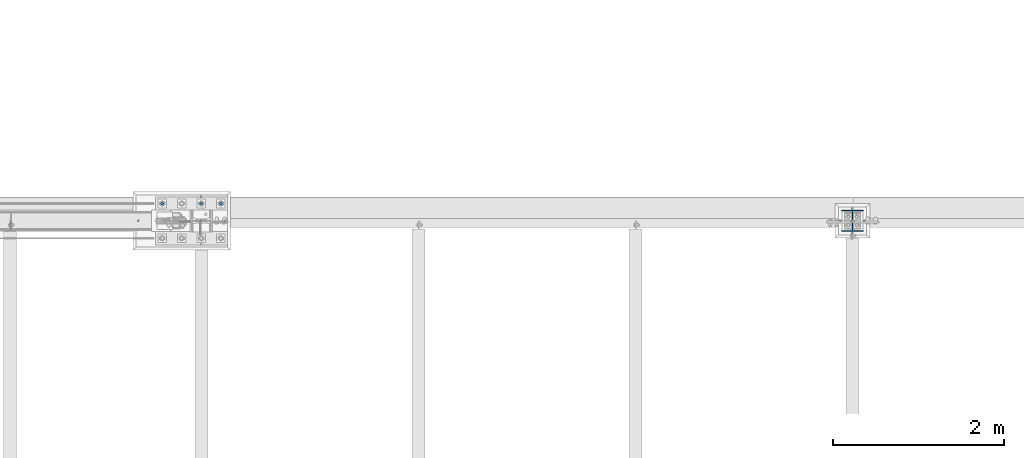
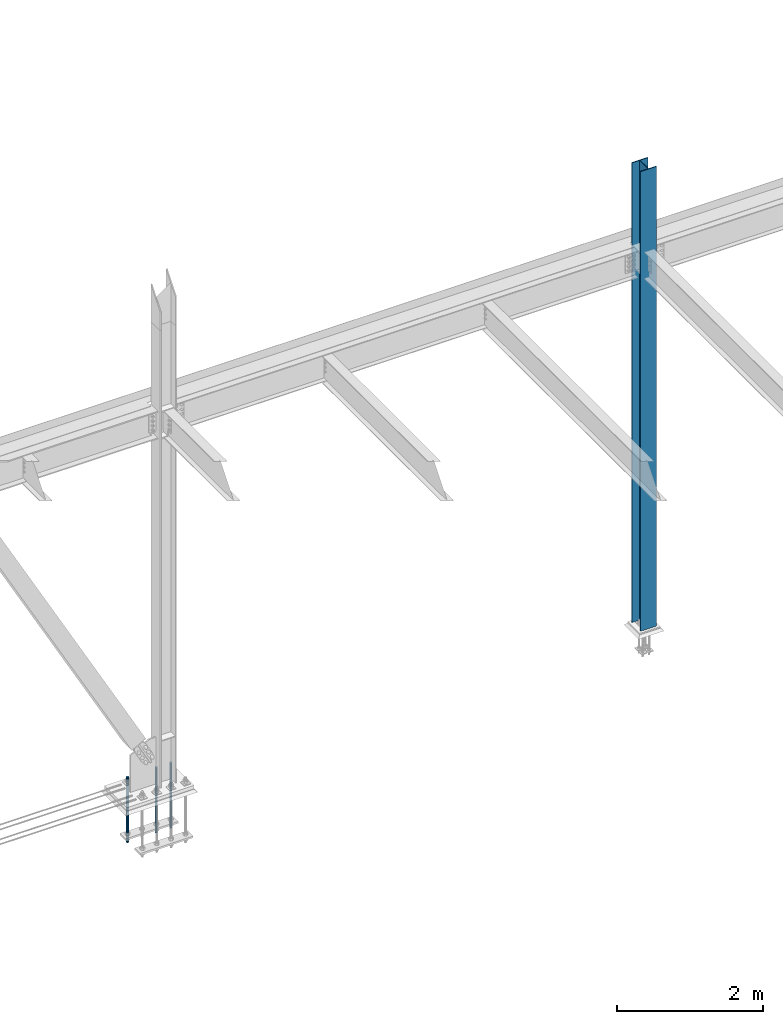
# One storey, part 1401 of 3843: 4 columns, 2 elements without a shape of their own.
"""IFC2X3 building model written with IfcOpenShell, lengths in millimetres."""

import ifcopenshell
import ifcopenshell.guid

model = None  # the IFC model being written
_history = None  # IfcOwnerHistory: only IFC2X3 demands one
_inside = {}  # id of a spatial element -> (the spatial element, [elements in it])
_under = {}  # id of a project, library or spatial element -> (it, [spatial elements below it])
_declared = {}  # id of a project -> (the project, [libraries it declares])
_typed = {}  # id of a type object -> (the type object, [elements of that type])
_made_of = {}  # id of a material, layer set ... -> (it, [elements and type objects made of it])


def new_model(schema):
    """Start an empty IFC model of exactly this schema.

    Asked for "IFC4X3", IfcOpenShell would pick the latest addendum, in which some entities
    have other attributes; the version numbers below select the first issue.
    IFC2X3 requires an IfcOwnerHistory on every rooted entity: one is made here for all.
    """
    global model, _history
    if schema == "IFC4X3":
        model = ifcopenshell.file(schema_version=(4, 3, 0, 0))
    else:
        model = ifcopenshell.file(schema=schema)
    _inside.clear()
    _under.clear()
    _declared.clear()
    _typed.clear()
    _made_of.clear()
    _history = None
    if model.schema == "IFC2X3":
        org = make("IfcOrganization", Name="unknown")
        user = make(
            "IfcPersonAndOrganization",
            ThePerson=make("IfcPerson", FamilyName="unknown"),
            TheOrganization=org,
        )
        app = make(
            "IfcApplication",
            ApplicationDeveloper=org,
            Version="unknown",
            ApplicationFullName="unknown",
            ApplicationIdentifier="unknown",
        )
        _history = make(
            "IfcOwnerHistory",
            OwningUser=user,
            OwningApplication=app,
            ChangeAction="ADDED",
            CreationDate=0,
        )
    return model


def make(cls, **values):
    """One entity of the class cls with the attributes given. An attribute that is None is left unset."""
    return model.create_entity(
        cls, **{name: value for name, value in values.items() if value is not None}
    )


def rooted(cls, **values):
    """An entity with a GlobalId (a new one), such as an element, a storey or a relation."""
    return make(cls, GlobalId=ifcopenshell.guid.new(), OwnerHistory=_history, **values)


def si_unit(unit_type, name, prefix=None):
    """IfcSIUnit, for example si_unit("LENGTHUNIT", "METRE", prefix="MILLI")."""
    return make("IfcSIUnit", UnitType=unit_type, Prefix=prefix, Name=name)


def assignment(units):
    """IfcUnitAssignment: the units of a project."""
    return None if units is None else make("IfcUnitAssignment", Units=units)


def point(xyz):
    """IfcCartesianPoint."""
    return None if xyz is None else make("IfcCartesianPoint", Coordinates=xyz)


def direction(xyz):
    """IfcDirection."""
    return None if xyz is None else make("IfcDirection", DirectionRatios=xyz)


def frame(location, z_axis=None, x_axis=None):
    """IfcAxis2Placement3D, a coordinate frame: its origin and axes. An axis left out is left unset."""
    return make(
        "IfcAxis2Placement3D",
        Location=point(location),
        Axis=direction(z_axis),
        RefDirection=direction(x_axis),
    )


def origin_with_axes():
    """The frame at (0, 0, 0) with the z axis (0, 0, 1) and the x axis (1, 0, 0) written out."""
    return frame((0.0, 0.0, 0.0), z_axis=(0.0, 0.0, 1.0), x_axis=(1.0, 0.0, 0.0))


def place(relative_to, where):
    """IfcLocalPlacement: puts the frame where relative to a parent placement (None: the world)."""
    return make(
        "IfcLocalPlacement", PlacementRelTo=relative_to, RelativePlacement=where
    )


def context(
    kind, dimensions, precision=None, world=None, true_north=None, identifier=None
):
    """IfcGeometricRepresentationContext, for example the 3D "Model" context."""
    return make(
        "IfcGeometricRepresentationContext",
        ContextIdentifier=identifier,
        ContextType=kind,
        CoordinateSpaceDimension=dimensions,
        Precision=precision,
        WorldCoordinateSystem=world,
        TrueNorth=true_north,
    )


def subcontext(parent, identifier, kind, view, scale=None):
    """IfcGeometricRepresentationSubContext, for example "Body" below "Model"."""
    return make(
        "IfcGeometricRepresentationSubContext",
        ContextIdentifier=identifier,
        ContextType=kind,
        ParentContext=parent,
        TargetScale=scale,
        TargetView=view,
    )


def project(units=None, contexts=None):
    """IfcProject with its units and contexts."""
    return rooted(
        "IfcProject",
        Name="project",
        RepresentationContexts=contexts,
        UnitsInContext=assignment(units),
    )


def spatial(cls, under=None, at=None, **own):
    """A site, building, storey or space (cls), placed at a placement, below another one or the project."""
    s = rooted(cls, ObjectPlacement=at, **own)
    if under is not None:
        _under.setdefault(under.id(), (under, []))[1].append(s)
    return s


def faces_of(points, faces, orient=None, outer=None):
    """IfcFace entities. A face is a list of loops; a loop is a list of indices into points, from 0.

    orient and outer hold one flag for each loop. By default every Orientation is true, the
    first loop of a face is its IfcFaceOuterBound and the others are IfcFaceBound.
    """
    made = []
    for i, loops in enumerate(faces):
        bounds = []
        for j, loop in enumerate(loops):
            is_outer = j == 0 if outer is None else outer[i][j]
            bounds.append(
                make(
                    "IfcFaceOuterBound" if is_outer else "IfcFaceBound",
                    Bound=make("IfcPolyLoop", Polygon=[points[k] for k in loop]),
                    Orientation=True if orient is None else orient[i][j],
                )
            )
        made.append(make("IfcFace", Bounds=bounds))
    return made


def faceted_brep(points, faces, orient=None, outer=None, voids=None):
    """IfcFacetedBrep: a solid bounded by flat faces; with voids (closed shells), ...WithVoids."""
    shared = [point(p) for p in points]
    hull = make("IfcClosedShell", CfsFaces=faces_of(shared, faces, orient, outer))
    if voids is None:
        return make("IfcFacetedBrep", Outer=hull)
    return make(
        "IfcFacetedBrepWithVoids",
        Outer=hull,
        Voids=[
            make(cls, CfsFaces=faces_of(shared, fs, o, b)) for cls, fs, o, b in voids
        ],
    )


def shape(context_of_items, identifier, shape_type, items):
    """IfcShapeRepresentation: the items that make up one representation, for example the "Body"."""
    return make(
        "IfcShapeRepresentation",
        ContextOfItems=context_of_items,
        RepresentationIdentifier=identifier,
        RepresentationType=shape_type,
        Items=items,
    )


def material(Name=None, Category=None):
    """IfcMaterial."""
    return make("IfcMaterial", Name=Name, Category=Category)


def made_of(thing, what):
    """Note that an element or type object is made of a material, layer set ...; save() writes the relation."""
    if what is not None:
        _made_of.setdefault(what.id(), (what, []))[1].append(thing)
    return thing


def type_object(cls, material=None, **own):
    """A type object (cls), such as IfcWallType, which elements share."""
    return made_of(rooted(cls, **own), material)


def element(
    cls,
    number,
    at=None,
    inside=None,
    cuts=None,
    type_object=None,
    material=None,
    context=None,
    identifier="Body",
    shape_type=None,
    held_by="IfcProductDefinitionShape",
    body=None,
    shapes=None,
    **own,
):
    """One element of the class cls, such as IfcWall. Its Tag is "e" and its number.

    at: its placement. inside: the storey or other place that contains it. cuts: it is an
    opening in that element (IfcRelVoidsElement). A single representation is given by context,
    identifier, shape_type and body (its items); several are given by shapes. held_by: the class
    of the entity that holds the representations. save() writes the other relations.
    """
    e = rooted(cls, Tag="e%d" % number, ObjectPlacement=at, **own)
    if body is not None:
        shapes = [shape(context, identifier, shape_type, body)]
    if shapes is not None:
        e.Representation = make(held_by, Representations=shapes)
    if inside is not None:
        _inside.setdefault(inside.id(), (inside, []))[1].append(e)
    if cuts is not None:
        rooted(
            "IfcRelVoidsElement", RelatingBuildingElement=cuts, RelatedOpeningElement=e
        )
    if type_object is not None:
        _typed.setdefault(type_object.id(), (type_object, []))[1].append(e)
    return made_of(e, material)


def aggregate(whole, parts):
    """IfcRelAggregates: a whole, such as a stair, and the parts it consists of."""
    return rooted("IfcRelAggregates", RelatingObject=whole, RelatedObjects=parts)


def save(model, path):
    """Write the relations noted so far, then the file.

    IfcRelAggregates (storeys below a building ...), IfcRelContainedInSpatialStructure (elements
    in a storey), IfcRelDefinesByType, IfcRelAssociatesMaterial and IfcRelDeclares: one each for
    every whole, place, type object, material and project.
    """
    for whole, parts in _under.values():
        aggregate(whole, parts)
    for where, things in _inside.values():
        rooted(
            "IfcRelContainedInSpatialStructure",
            RelatedElements=things,
            RelatingStructure=where,
        )
    for kind, things in _typed.values():
        rooted("IfcRelDefinesByType", RelatedObjects=things, RelatingType=kind)
    for what, things in _made_of.values():
        rooted("IfcRelAssociatesMaterial", RelatedObjects=things, RelatingMaterial=what)
    for by, libraries in _declared.values():
        rooted("IfcRelDeclares", RelatingContext=by, RelatedDefinitions=libraries)
    model.write(path)


model = new_model("IFC2X3")

# Units and contexts
model_context = context("Model", 3, precision=1e-05, world=origin_with_axes())
body_context = subcontext(model_context, "Body", "Model", "MODEL_VIEW")
ifc_project = project(units=[si_unit("LENGTHUNIT", "METRE", prefix="MILLI"), si_unit("AREAUNIT", "SQUARE_METRE"), si_unit("VOLUMEUNIT", "CUBIC_METRE"), si_unit("MASSUNIT", "GRAM", prefix="KILO"), si_unit("TIMEUNIT", "SECOND"), si_unit("PLANEANGLEUNIT", "RADIAN"), si_unit("SOLIDANGLEUNIT", "STERADIAN"), si_unit("THERMODYNAMICTEMPERATUREUNIT", "DEGREE_CELSIUS"), si_unit("LUMINOUSINTENSITYUNIT", "LUMEN")], contexts=[model_context])

# Site, building, storey
site_placement = place(None, origin_with_axes())
site = spatial("IfcSite", under=ifc_project, at=site_placement, CompositionType="ELEMENT")
building_placement = place(site_placement, origin_with_axes())
building = spatial("IfcBuilding", under=site, at=building_placement, Name="Undefined", CompositionType="ELEMENT")
storey_placement = place(building_placement, origin_with_axes())
storey = spatial("IfcBuildingStorey", under=building, at=storey_placement, Name="Undefined", CompositionType="ELEMENT", Elevation=0.0)

# Assembly, columns
assembly_1_placement = place(storey_placement, origin_with_axes())
assembly_1 = element("IfcElementAssembly", 1, at=assembly_1_placement, inside=storey, Name="TEMPLATE", AssemblyPlace="NOTDEFINED", PredefinedType="RIGID_FRAME")
ifc_material_1 = material(Name="Undefined/F1554-GR.55")
column_type_1 = type_object("IfcColumnType", PredefinedType="NOTDEFINED")
column_1_placement = place(assembly_1_placement, frame((62865.0, 104762.3, 30022.8), z_axis=(-1.0, 0.0, 0.0), x_axis=(0.0, 0.0, -1.0)))
column_1 = element("IfcColumn", 2, at=column_1_placement, type_object=column_type_1, material=ifc_material_1, Name="ANCHOR_ROD", context=body_context, shape_type="Brep", body=[
    faceted_brep([(-209.549999999999, -16.0214699700155, 9.25), (-209.549999999999, -9.25, 16.0214699700118), (-209.549999999999, 0.0, 18.5), (-209.549999999999, 9.25, 16.0214699700118), (-209.549999999999, 16.0214699700155, 9.25), (-209.549999999999, 18.5, 0.0), (-209.549999999999, 16.0214699700155, -9.25), (-209.549999999999, 9.25, -16.0214699700118), (-209.549999999999, 0.0, -18.5), (-209.549999999999, -9.25, -16.0214699700118), (-209.549999999999, -16.0214699700155, -9.25), (-209.549999999999, -18.5, 0.0), (0.0, 18.5, 0.0), (0.0, 16.0214699700118, -9.25), (0.0, 9.25, -16.0214699700155), (0.0, 0.0, -18.5), (0.0, -9.25, -16.0214699700155), (0.0, -16.0214699700118, -9.25), (0.0, -18.5, 0.0), (0.0, -16.0214699700118, 9.25), (0.0, -9.25, 16.0214699700155), (0.0, 0.0, 18.5), (0.0, 9.25, 16.0214699700155), (0.0, 16.0214699700118, 9.25), (0.0, -16.4977839420972, 9.52500000000146), (0.0, -9.52500000000146, 16.4977839420972), (0.0, 0.0, 19.0499989999989), (0.0, 9.52500000000146, 16.4977839420972), (0.0, 16.4977839420972, 9.52500000000146), (0.0, 19.0500000000029, 0.0), (0.0, 16.4977839420972, -9.52500000000146), (0.0, 9.52500000000146, -16.4977839420972), (0.0, 0.0, -19.0499989999989), (0.0, -9.52500000000146, -16.4977839420972), (0.0, -16.4977839420972, -9.52500000000146), (0.0, -19.0500000000029, 0.0), (698.5, -19.0499999999993, 0.0), (698.5, -16.4977839420935, 9.52499999999418), (698.5, -9.52500000000146, 16.4977839420899), (698.5, 0.0, 19.0500000000029), (698.5, 9.52500000000146, 16.4977839420899), (698.5, 16.4977839420935, 9.52499999999418), (698.5, 19.0499999999993, 0.0), (698.5, 16.4977839420935, -9.52499999999418), (698.5, 9.52500000000146, -16.4977839420899), (698.5, 0.0, -19.0500000000029), (698.5, -9.52500000000146, -16.4977839420899), (698.5, -16.4977839420935, -9.52499999999418), (698.5, -9.25, 16.0214699700155), (698.5, 0.0, 18.5), (698.5, 9.25, 16.0214699700155), (698.5, 16.0214699700118, 9.25), (698.5, 18.5, 0.0), (698.5, 16.0214699700118, -9.25), (698.5, 9.25, -16.0214699700155), (698.5, 0.0, -18.5), (698.5, -9.25, -16.0214699700155), (698.5, -16.0214699700118, -9.25), (698.5, -18.5, 0.0), (698.5, -16.0214699700118, 9.25), (889.0, -9.25, -16.0214699700155), (889.0, 0.0, -18.5), (889.0, 9.25, -16.0214699700155), (889.0, 16.0214699700118, -9.25), (889.0, 18.5, 0.0), (889.0, 16.0214699700118, 9.25), (889.0, 9.25, 16.0214699700155), (889.0, 0.0, 18.5), (889.0, -9.25, 16.0214699700155), (889.0, -16.0214699700118, 9.25), (889.0, -18.5, 0.0), (889.0, -16.0214699700118, -9.25)], [[[0, 1, 2, 3, 4, 5, 6, 7, 8, 9, 10, 11]], [[6, 5, 12, 13]], [[7, 6, 13, 14]], [[8, 7, 14, 15]], [[9, 8, 15, 16]], [[10, 9, 16, 17]], [[11, 10, 17, 18]], [[0, 11, 18, 19]], [[1, 0, 19, 20]], [[2, 1, 20, 21]], [[3, 2, 21, 22]], [[4, 3, 22, 23]], [[5, 4, 23, 12]], [[24, 25, 26, 27, 28, 29, 30, 31, 32, 33, 34, 35], [22, 21, 20, 19, 18, 17, 16, 15, 14, 13, 12, 23]], [[24, 35, 36, 37]], [[25, 24, 37, 38]], [[26, 25, 38, 39]], [[27, 26, 39, 40]], [[28, 27, 40, 41]], [[29, 28, 41, 42]], [[30, 29, 42, 43]], [[31, 30, 43, 44]], [[32, 31, 44, 45]], [[33, 32, 45, 46]], [[34, 33, 46, 47]], [[35, 34, 47, 36]], [[46, 45, 44, 43, 42, 41, 40, 39, 38, 37, 36, 47], [48, 49, 50, 51, 52, 53, 54, 55, 56, 57, 58, 59]], [[60, 61, 62, 63, 64, 65, 66, 67, 68, 69, 70, 71]], [[68, 67, 49, 48]], [[69, 68, 48, 59]], [[70, 69, 59, 58]], [[71, 70, 58, 57]], [[60, 71, 57, 56]], [[61, 60, 56, 55]], [[62, 61, 55, 54]], [[63, 62, 54, 53]], [[64, 63, 53, 52]], [[65, 64, 52, 51]], [[66, 65, 51, 50]], [[67, 66, 50, 49]]]),
])
column_2_placement = place(assembly_1_placement, frame((62636.4, 104762.3, 30022.8), z_axis=(-1.0, 0.0, 0.0), x_axis=(0.0, 0.0, -1.0)))
column_2 = element("IfcColumn", 3, at=column_2_placement, type_object=column_type_1, material=ifc_material_1, Name="ANCHOR_ROD", context=body_context, shape_type="Brep", body=[
    faceted_brep([(-209.549999999999, -16.0214699700155, 9.25), (-209.549999999999, -9.25, 16.0214699700118), (-209.549999999999, 0.0, 18.5), (-209.549999999999, 9.25, 16.0214699700118), (-209.549999999999, 16.0214699700155, 9.25), (-209.549999999999, 18.5, 0.0), (-209.549999999999, 16.0214699700155, -9.25), (-209.549999999999, 9.25, -16.0214699700118), (-209.549999999999, 0.0, -18.5), (-209.549999999999, -9.25, -16.0214699700118), (-209.549999999999, -16.0214699700155, -9.25), (-209.549999999999, -18.5, 0.0), (0.0, 18.5, 0.0), (0.0, 16.0214699700118, -9.25), (0.0, 9.25, -16.0214699700155), (0.0, 0.0, -18.5), (0.0, -9.25, -16.0214699700155), (0.0, -16.0214699700118, -9.25), (0.0, -18.5, 0.0), (0.0, -16.0214699700118, 9.25), (0.0, -9.25, 16.0214699700155), (0.0, 0.0, 18.5), (0.0, 9.25, 16.0214699700155), (0.0, 16.0214699700118, 9.25), (0.0, -16.4977839420972, 9.52500000000146), (0.0, -9.52500000000146, 16.4977839420972), (0.0, 0.0, 19.0499989999989), (0.0, 9.52500000000146, 16.4977839420972), (0.0, 16.4977839420972, 9.52500000000146), (0.0, 19.0500000000029, 0.0), (0.0, 16.4977839420972, -9.52500000000146), (0.0, 9.52500000000146, -16.4977839420972), (0.0, 0.0, -19.0499989999989), (0.0, -9.52500000000146, -16.4977839420972), (0.0, -16.4977839420972, -9.52500000000146), (0.0, -19.0500000000029, 0.0), (698.5, -19.0499999999993, 0.0), (698.5, -16.4977839420935, 9.52499999999418), (698.5, -9.52500000000146, 16.4977839420899), (698.5, 0.0, 19.0500000000029), (698.5, 9.52500000000146, 16.4977839420899), (698.5, 16.4977839420935, 9.52499999999418), (698.5, 19.0499999999993, 0.0), (698.5, 16.4977839420935, -9.52499999999418), (698.5, 9.52500000000146, -16.4977839420899), (698.5, 0.0, -19.0500000000029), (698.5, -9.52500000000146, -16.4977839420899), (698.5, -16.4977839420935, -9.52499999999418), (698.5, -9.25, 16.0214699700155), (698.5, 0.0, 18.5), (698.5, 9.25, 16.0214699700155), (698.5, 16.0214699700118, 9.25), (698.5, 18.5, 0.0), (698.5, 16.0214699700118, -9.25), (698.5, 9.25, -16.0214699700155), (698.5, 0.0, -18.5), (698.5, -9.25, -16.0214699700155), (698.5, -16.0214699700118, -9.25), (698.5, -18.5, 0.0), (698.5, -16.0214699700118, 9.25), (889.0, -9.25, -16.0214699700155), (889.0, 0.0, -18.5), (889.0, 9.25, -16.0214699700155), (889.0, 16.0214699700118, -9.25), (889.0, 18.5, 0.0), (889.0, 16.0214699700118, 9.25), (889.0, 9.25, 16.0214699700155), (889.0, 0.0, 18.5), (889.0, -9.25, 16.0214699700155), (889.0, -16.0214699700118, 9.25), (889.0, -18.5, 0.0), (889.0, -16.0214699700118, -9.25)], [[[0, 1, 2, 3, 4, 5, 6, 7, 8, 9, 10, 11]], [[6, 5, 12, 13]], [[7, 6, 13, 14]], [[8, 7, 14, 15]], [[9, 8, 15, 16]], [[10, 9, 16, 17]], [[11, 10, 17, 18]], [[0, 11, 18, 19]], [[1, 0, 19, 20]], [[2, 1, 20, 21]], [[3, 2, 21, 22]], [[4, 3, 22, 23]], [[5, 4, 23, 12]], [[24, 25, 26, 27, 28, 29, 30, 31, 32, 33, 34, 35], [22, 21, 20, 19, 18, 17, 16, 15, 14, 13, 12, 23]], [[24, 35, 36, 37]], [[25, 24, 37, 38]], [[26, 25, 38, 39]], [[27, 26, 39, 40]], [[28, 27, 40, 41]], [[29, 28, 41, 42]], [[30, 29, 42, 43]], [[31, 30, 43, 44]], [[32, 31, 44, 45]], [[33, 32, 45, 46]], [[34, 33, 46, 47]], [[35, 34, 47, 36]], [[46, 45, 44, 43, 42, 41, 40, 39, 38, 37, 36, 47], [48, 49, 50, 51, 52, 53, 54, 55, 56, 57, 58, 59]], [[60, 61, 62, 63, 64, 65, 66, 67, 68, 69, 70, 71]], [[68, 67, 49, 48]], [[69, 68, 48, 59]], [[70, 69, 59, 58]], [[71, 70, 58, 57]], [[60, 71, 57, 56]], [[61, 60, 56, 55]], [[62, 61, 55, 54]], [[63, 62, 54, 53]], [[64, 63, 53, 52]], [[65, 64, 52, 51]], [[66, 65, 51, 50]], [[67, 66, 50, 49]]]),
])
column_3_placement = place(assembly_1_placement, frame((62179.2, 104762.3, 30022.8), z_axis=(-1.0, 0.0, 0.0), x_axis=(0.0, 0.0, -1.0)))
column_3 = element("IfcColumn", 4, at=column_3_placement, type_object=column_type_1, material=ifc_material_1, Name="ANCHOR_ROD", context=body_context, shape_type="Brep", body=[
    faceted_brep([(-209.549999999999, -16.0214699700155, 9.25), (-209.549999999999, -9.25, 16.0214699700118), (-209.549999999999, 0.0, 18.5), (-209.549999999999, 9.25, 16.0214699700118), (-209.549999999999, 16.0214699700155, 9.25), (-209.549999999999, 18.5, 0.0), (-209.549999999999, 16.0214699700155, -9.25), (-209.549999999999, 9.25, -16.0214699700118), (-209.549999999999, 0.0, -18.5), (-209.549999999999, -9.25, -16.0214699700118), (-209.549999999999, -16.0214699700155, -9.25), (-209.549999999999, -18.5, 0.0), (0.0, 18.5, 0.0), (0.0, 16.0214699700118, -9.25), (0.0, 9.25, -16.0214699700155), (0.0, 0.0, -18.5), (0.0, -9.25, -16.0214699700155), (0.0, -16.0214699700118, -9.25), (0.0, -18.5, 0.0), (0.0, -16.0214699700118, 9.25), (0.0, -9.25, 16.0214699700155), (0.0, 0.0, 18.5), (0.0, 9.25, 16.0214699700155), (0.0, 16.0214699700118, 9.25), (0.0, -16.4977839420972, 9.52500000000146), (0.0, -9.52500000000146, 16.4977839420972), (0.0, 0.0, 19.0499989999989), (0.0, 9.52500000000146, 16.4977839420972), (0.0, 16.4977839420972, 9.52500000000146), (0.0, 19.0500000000029, 0.0), (0.0, 16.4977839420972, -9.52500000000146), (0.0, 9.52500000000146, -16.4977839420972), (0.0, 0.0, -19.0499989999989), (0.0, -9.52500000000146, -16.4977839420972), (0.0, -16.4977839420972, -9.52500000000146), (0.0, -19.0500000000029, 0.0), (698.5, -19.0499999999993, 0.0), (698.5, -16.4977839420935, 9.52499999999418), (698.5, -9.52500000000146, 16.4977839420899), (698.5, 0.0, 19.0500000000029), (698.5, 9.52500000000146, 16.4977839420899), (698.5, 16.4977839420935, 9.52499999999418), (698.5, 19.0499999999993, 0.0), (698.5, 16.4977839420935, -9.52499999999418), (698.5, 9.52500000000146, -16.4977839420899), (698.5, 0.0, -19.0500000000029), (698.5, -9.52500000000146, -16.4977839420899), (698.5, -16.4977839420935, -9.52499999999418), (698.5, -9.25, 16.0214699700155), (698.5, 0.0, 18.5), (698.5, 9.25, 16.0214699700155), (698.5, 16.0214699700118, 9.25), (698.5, 18.5, 0.0), (698.5, 16.0214699700118, -9.25), (698.5, 9.25, -16.0214699700155), (698.5, 0.0, -18.5), (698.5, -9.25, -16.0214699700155), (698.5, -16.0214699700118, -9.25), (698.5, -18.5, 0.0), (698.5, -16.0214699700118, 9.25), (889.0, -9.25, -16.0214699700155), (889.0, 0.0, -18.5), (889.0, 9.25, -16.0214699700155), (889.0, 16.0214699700118, -9.25), (889.0, 18.5, 0.0), (889.0, 16.0214699700118, 9.25), (889.0, 9.25, 16.0214699700155), (889.0, 0.0, 18.5), (889.0, -9.25, 16.0214699700155), (889.0, -16.0214699700118, 9.25), (889.0, -18.5, 0.0), (889.0, -16.0214699700118, -9.25)], [[[0, 1, 2, 3, 4, 5, 6, 7, 8, 9, 10, 11]], [[6, 5, 12, 13]], [[7, 6, 13, 14]], [[8, 7, 14, 15]], [[9, 8, 15, 16]], [[10, 9, 16, 17]], [[11, 10, 17, 18]], [[0, 11, 18, 19]], [[1, 0, 19, 20]], [[2, 1, 20, 21]], [[3, 2, 21, 22]], [[4, 3, 22, 23]], [[5, 4, 23, 12]], [[24, 25, 26, 27, 28, 29, 30, 31, 32, 33, 34, 35], [22, 21, 20, 19, 18, 17, 16, 15, 14, 13, 12, 23]], [[24, 35, 36, 37]], [[25, 24, 37, 38]], [[26, 25, 38, 39]], [[27, 26, 39, 40]], [[28, 27, 40, 41]], [[29, 28, 41, 42]], [[30, 29, 42, 43]], [[31, 30, 43, 44]], [[32, 31, 44, 45]], [[33, 32, 45, 46]], [[34, 33, 46, 47]], [[35, 34, 47, 36]], [[46, 45, 44, 43, 42, 41, 40, 39, 38, 37, 36, 47], [48, 49, 50, 51, 52, 53, 54, 55, 56, 57, 58, 59]], [[60, 61, 62, 63, 64, 65, 66, 67, 68, 69, 70, 71]], [[68, 67, 49, 48]], [[69, 68, 48, 59]], [[70, 69, 59, 58]], [[71, 70, 58, 57]], [[60, 71, 57, 56]], [[61, 60, 56, 55]], [[62, 61, 55, 54]], [[63, 62, 54, 53]], [[64, 63, 53, 52]], [[65, 64, 52, 51]], [[66, 65, 51, 50]], [[67, 66, 50, 49]]]),
])
aggregate(assembly_1, [column_1, column_2, column_3])

# Assembly, column
assembly_2_placement = place(storey_placement, origin_with_axes())
assembly_2 = element("IfcElementAssembly", 5, at=assembly_2_placement, inside=storey, Name="COLUMN", AssemblyPlace="NOTDEFINED", PredefinedType="RIGID_FRAME")
ifc_material_2 = material(Name="STEEL/A992")
column_type_2 = type_object("IfcColumnType", Name="W10X49", PredefinedType="NOTDEFINED")
column_4_placement = place(assembly_2_placement, frame((70256.4, 104559.1, 30022.8), z_axis=(0.0, 1.0, 0.0), x_axis=(0.0, 0.0, 1.0)))
column_4 = element("IfcColumn", 6, at=column_4_placement, type_object=column_type_2, material=ifc_material_2, Name="COLUMN", ObjectType="W10X49", context=body_context, shape_type="Brep", body=[
    faceted_brep([(63.4999999999964, 127.0, -127.0), (63.4999999999964, 127.0, -112.712499999994), (7772.4, 127.0, -112.712499999994), (7772.4, 127.0, -127.0), (63.4999999999964, 3.96875, -112.7125), (7772.4, 3.96875, -112.712499999994), (63.4999999999964, 3.96875, 112.7125), (7772.4, 3.96875, 112.712499999994), (63.4999999999964, 127.0, 112.712499999994), (7772.4, 127.0, 112.712499999994), (63.4999999999964, 127.0, 127.0), (7772.4, 127.0, 127.0), (63.4999999999964, -127.0, 127.0), (7772.4, -127.0, 127.0), (63.4999999999964, -127.0, 112.712499999994), (7772.4, -127.0, 112.712499999994), (63.4999999999964, -3.96875, 112.7125), (7772.4, -3.96875, 112.712499999994), (63.4999999999964, -3.96875, -112.7125), (7772.4, -3.96875, -112.712499999994), (63.4999999999964, -127.0, -112.712499999994), (7772.4, -127.0, -112.712499999994), (63.4999999999964, -127.0, -127.0), (7772.4, -127.0, -127.0)], [[[0, 1, 2, 3]], [[1, 4, 5, 2]], [[4, 6, 7, 5]], [[6, 8, 9, 7]], [[8, 10, 11, 9]], [[10, 12, 13, 11]], [[12, 14, 15, 13]], [[14, 16, 17, 15]], [[16, 18, 19, 17]], [[18, 20, 21, 19]], [[20, 22, 23, 21]], [[22, 0, 3, 23]], [[5, 7, 9, 11, 13, 15, 17, 19, 21, 23, 3, 2]], [[22, 20, 18, 16, 14, 12, 10, 8, 6, 4, 1, 0]]]),
])
aggregate(assembly_2, [column_4])

save(model, "model.ifc")
